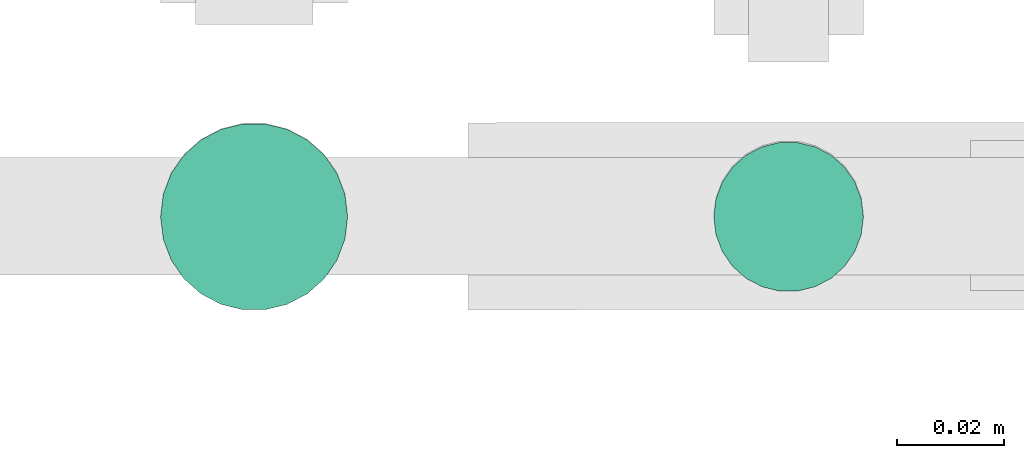
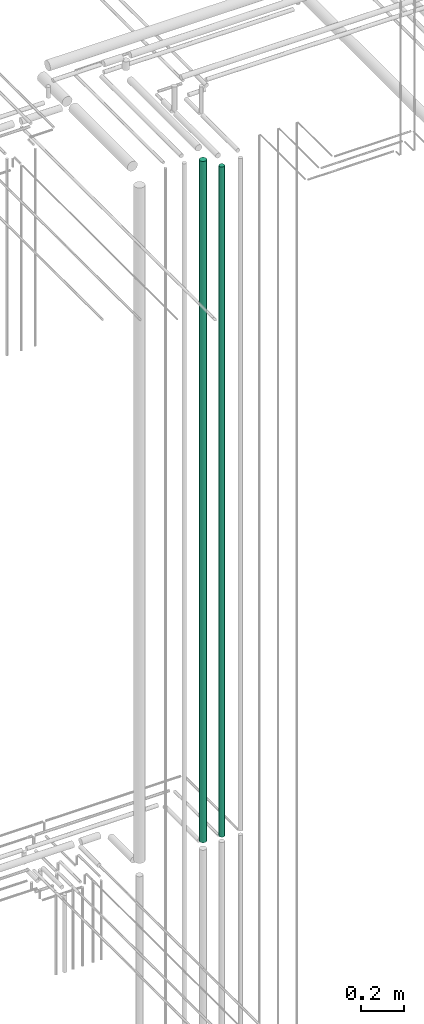
# One storey, part 81 of 331: 2 flow segments.
"""IFC2X3 building model written with IfcOpenShell, lengths in millimetres."""

from ifc_helpers import new_model, entity, si_unit, converted_unit, derived_unit, direction, frame, frame_2d, origin, origin_2d_with_axis, place, context, subcontext, project, spatial, circle, extrude, type_object, element, save


model = new_model("IFC2X3")

# Units and contexts
model_context = context("Model", 3, precision=0.01, world=origin(), true_north=direction((6.12303176911189e-17, 1.0)))
body_context = subcontext(model_context, "Body", "Model", "MODEL_VIEW")
ifc_project = project(units=[si_unit("LENGTHUNIT", "METRE", prefix="MILLI"), si_unit("AREAUNIT", "SQUARE_METRE"), si_unit("VOLUMEUNIT", "CUBIC_METRE"), converted_unit("PLANEANGLEUNIT", "DEGREE", entity("IfcRatioMeasure", 0.0174532925199433), si_unit("PLANEANGLEUNIT", "RADIAN"), dimensions=[0, 0, 0, 0, 0, 0, 0]), si_unit("MASSUNIT", "GRAM", prefix="KILO"), derived_unit("MASSDENSITYUNIT", [(si_unit("MASSUNIT", "GRAM", prefix="KILO"), 1), (si_unit("LENGTHUNIT", "METRE"), -3)]), derived_unit("MOMENTOFINERTIAUNIT", [(si_unit("LENGTHUNIT", "METRE"), 4)]), si_unit("TIMEUNIT", "SECOND"), si_unit("FREQUENCYUNIT", "HERTZ"), si_unit("THERMODYNAMICTEMPERATUREUNIT", "DEGREE_CELSIUS"), derived_unit("THERMALTRANSMITTANCEUNIT", [(si_unit("MASSUNIT", "GRAM", prefix="KILO"), 1), (si_unit("THERMODYNAMICTEMPERATUREUNIT", "KELVIN"), -1), (si_unit("TIMEUNIT", "SECOND"), -3)]), derived_unit("VOLUMETRICFLOWRATEUNIT", [(si_unit("LENGTHUNIT", "METRE"), 3), (si_unit("TIMEUNIT", "SECOND"), -1)]), derived_unit("MASSFLOWRATEUNIT", [(si_unit("MASSUNIT", "GRAM", prefix="KILO"), 1), (si_unit("TIMEUNIT", "SECOND"), -1)]), derived_unit("ROTATIONALFREQUENCYUNIT", [(si_unit("TIMEUNIT", "SECOND"), -1)]), si_unit("ELECTRICCURRENTUNIT", "AMPERE"), si_unit("ELECTRICVOLTAGEUNIT", "VOLT"), si_unit("POWERUNIT", "WATT"), si_unit("FORCEUNIT", "NEWTON", prefix="KILO"), si_unit("ILLUMINANCEUNIT", "LUX"), si_unit("LUMINOUSFLUXUNIT", "LUMEN"), si_unit("LUMINOUSINTENSITYUNIT", "CANDELA"), derived_unit("USERDEFINED", [(si_unit("MASSUNIT", "GRAM", prefix="KILO"), -1), (si_unit("LENGTHUNIT", "METRE"), -2), (si_unit("TIMEUNIT", "SECOND"), 3), (si_unit("LUMINOUSFLUXUNIT", "LUMEN"), 1)]), derived_unit("LINEARVELOCITYUNIT", [(si_unit("LENGTHUNIT", "METRE"), 1), (si_unit("TIMEUNIT", "SECOND"), -1)]), si_unit("PRESSUREUNIT", "PASCAL"), derived_unit("USERDEFINED", [(si_unit("LENGTHUNIT", "METRE"), -2), (si_unit("MASSUNIT", "GRAM", prefix="KILO"), 1), (si_unit("TIMEUNIT", "SECOND"), -2)]), derived_unit("LINEARFORCEUNIT", [(si_unit("MASSUNIT", "GRAM", prefix="KILO"), 1), (si_unit("LENGTHUNIT", "METRE"), 1), (si_unit("TIMEUNIT", "SECOND"), -2), (si_unit("LENGTHUNIT", "METRE"), -1)]), derived_unit("PLANARFORCEUNIT", [(si_unit("MASSUNIT", "GRAM", prefix="KILO"), 1), (si_unit("LENGTHUNIT", "METRE"), 1), (si_unit("TIMEUNIT", "SECOND"), -2), (si_unit("LENGTHUNIT", "METRE"), -2)])], contexts=[model_context])

# Site, building, storey
site_placement = place(None, frame((0.0, -0.00077364408347762, 0.0)))
site = spatial("IfcSite", under=ifc_project, at=site_placement, CompositionType="ELEMENT")
building_placement = place(site_placement, origin())
building = spatial("IfcBuilding", under=site, at=building_placement, CompositionType="ELEMENT")
storey_placement = place(building_placement, origin())
storey = spatial("IfcBuildingStorey", under=building, at=storey_placement, CompositionType="ELEMENT", Elevation=0.0)

# Flow segments
pipe_segment_type = type_object("IfcPipeSegmentType", PredefinedType="NOTDEFINED")
flow_segment_1_placement = place(building_placement, frame((64135.5166110417, 8132.33499464522, 14565.0)))
element("IfcFlowSegment", 1, at=flow_segment_1_placement, inside=storey, type_object=pipe_segment_type, context=body_context, shape_type="SweptSolid", body=[
    extrude(circle(Radius=14.0, at=frame_2d((0.0, -1.08286712929839e-12), x_axis=(1.0, 0.0))), frame((15.5952722359127, 15.5952722359149, 0.0), z_axis=(0.0, 0.0, 1.0), x_axis=(-1.0, 0.0, 0.0)), (0.0, 0.0, 1.0), 3775.99999999999),
])
flow_segment_2_placement = place(building_placement, frame((64032.0166110417, 8128.83499464522, 14571.0)))
element("IfcFlowSegment", 2, at=flow_segment_2_placement, inside=storey, type_object=pipe_segment_type, context=body_context, shape_type="SweptSolid", body=[
    extrude(circle(Radius=17.5, at=origin_2d_with_axis()), frame((19.0952722359119, 19.0952722359163, 0.0), z_axis=(0.0, 0.0, 1.0), x_axis=(-1.0, 0.0, 0.0)), (0.0, 0.0, 1.0), 3839.00000000003),
])

save(model, "model.ifc")
